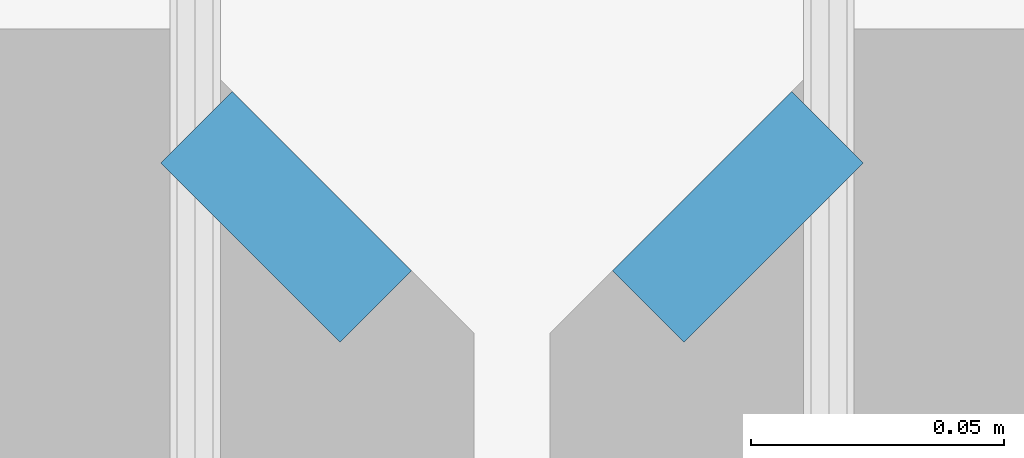
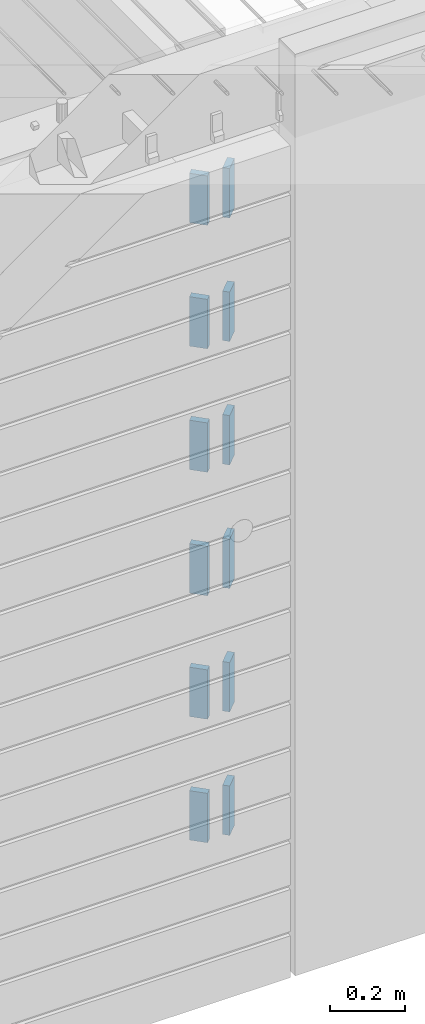
# One storey, part 206 of 341: 12 plates, 14 elements without a shape of their own.
"""IFC2X3 building model written with IfcOpenShell, lengths in millimetres."""

from ifc_helpers import new_model, si_unit, frame, origin_with_axes, place, context, subcontext, project, spatial, faceted_brep, material, type_object, element, aggregate, save


model = new_model("IFC2X3")

# Units and contexts
model_context = context("Model", 3, precision=1e-05, world=origin_with_axes())
body_context = subcontext(model_context, "Body", "Model", "MODEL_VIEW")
ifc_project = project(units=[si_unit("LENGTHUNIT", "METRE", prefix="MILLI"), si_unit("AREAUNIT", "SQUARE_METRE"), si_unit("VOLUMEUNIT", "CUBIC_METRE"), si_unit("MASSUNIT", "GRAM", prefix="KILO"), si_unit("TIMEUNIT", "SECOND"), si_unit("PLANEANGLEUNIT", "RADIAN"), si_unit("SOLIDANGLEUNIT", "STERADIAN"), si_unit("THERMODYNAMICTEMPERATUREUNIT", "DEGREE_CELSIUS"), si_unit("LUMINOUSINTENSITYUNIT", "LUMEN")], contexts=[model_context])

# Site, building, storey
site_placement = place(None, origin_with_axes())
site = spatial("IfcSite", under=ifc_project, at=site_placement, CompositionType="ELEMENT")
building_placement = place(site_placement, origin_with_axes())
building = spatial("IfcBuilding", under=site, at=building_placement, CompositionType="ELEMENT")
storey_placement = place(building_placement, origin_with_axes())
storey = spatial("IfcBuildingStorey", under=building, at=storey_placement, Name="5", CompositionType="ELEMENT", Elevation=0.0)

# Assemblies, plates
assembly_1_placement = place(storey_placement, origin_with_axes())
assembly_1 = element("IfcElementAssembly", 1, at=assembly_1_placement, inside=storey, AssemblyPlace="NOTDEFINED", PredefinedType="REINFORCEMENT_UNIT")
assembly_2_placement = place(assembly_1_placement, origin_with_axes())
assembly_2 = element("IfcElementAssembly", 2, at=assembly_2_placement, Name="Steel Assembly", AssemblyPlace="NOTDEFINED", PredefinedType="RIGID_FRAME")
ifc_material = material(Name="STEEL/Steel_Undefined")
plate_type = type_object("IfcPlateType", PredefinedType="NOTDEFINED")
plate_1_placement = place(assembly_2_placement, frame((28641.4644660941, 7938.1801948466, 96042.5), z_axis=(-0.707106781186547, 0.707106781186548, 0.0), x_axis=(0.707106781186557, 0.707106781186538, 0.0)))
plate_1 = element("IfcPlate", 3, at=plate_1_placement, type_object=plate_type, material=ifc_material, Name="VL_080", context=body_context, shape_type="Brep", body=[
    faceted_brep([(0.0, -80.0, 0.0), (0.0, -80.0, 20.0), (0.0, 80.0, 20.0), (0.0, 80.0, 0.0), (50.0, -80.0, 20.0), (50.0, 80.0, 20.0), (50.0, -80.0, 0.0), (50.0, 80.0, 0.0)], [[[0, 1, 2, 3]], [[1, 4, 5, 2]], [[4, 6, 7, 5]], [[6, 0, 3, 7]], [[5, 7, 3, 2]], [[6, 4, 1, 0]]]),
])
aggregate(assembly_2, [plate_1])
assembly_3_placement = place(assembly_1_placement, origin_with_axes())
assembly_3 = element("IfcElementAssembly", 4, at=assembly_3_placement, Name="Steel Assembly", AssemblyPlace="NOTDEFINED", PredefinedType="RIGID_FRAME")
plate_2_placement = place(assembly_3_placement, frame((28641.4644660941, 7938.1801948466, 95642.5), z_axis=(-0.707106781186547, 0.707106781186548, 0.0), x_axis=(0.707106781186557, 0.707106781186538, 0.0)))
plate_2 = element("IfcPlate", 5, at=plate_2_placement, type_object=plate_type, material=ifc_material, Name="VL_080", context=body_context, shape_type="Brep", body=[
    faceted_brep([(0.0, -80.0, 0.0), (0.0, -80.0, 20.0), (0.0, 80.0, 20.0), (0.0, 80.0, 0.0), (50.0, -80.0, 20.0), (50.0, 80.0, 20.0), (50.0, -80.0, 0.0), (50.0, 80.0, 0.0)], [[[0, 1, 2, 3]], [[1, 4, 5, 2]], [[4, 6, 7, 5]], [[6, 0, 3, 7]], [[5, 7, 3, 2]], [[6, 4, 1, 0]]]),
])
aggregate(assembly_3, [plate_2])
assembly_4_placement = place(assembly_1_placement, origin_with_axes())
assembly_4 = element("IfcElementAssembly", 6, at=assembly_4_placement, Name="Steel Assembly", AssemblyPlace="NOTDEFINED", PredefinedType="RIGID_FRAME")
plate_3_placement = place(assembly_4_placement, frame((28641.4644660941, 7938.1801948466, 95242.5), z_axis=(-0.707106781186547, 0.707106781186548, 0.0), x_axis=(0.707106781186557, 0.707106781186538, 0.0)))
plate_3 = element("IfcPlate", 7, at=plate_3_placement, type_object=plate_type, material=ifc_material, Name="VL_080", context=body_context, shape_type="Brep", body=[
    faceted_brep([(0.0, -80.0, 0.0), (0.0, -80.0, 20.0), (0.0, 80.0, 20.0), (0.0, 80.0, 0.0), (50.0, -80.0, 20.0), (50.0, 80.0, 20.0), (50.0, -80.0, 0.0), (50.0, 80.0, 0.0)], [[[0, 1, 2, 3]], [[1, 4, 5, 2]], [[4, 6, 7, 5]], [[6, 0, 3, 7]], [[5, 7, 3, 2]], [[6, 4, 1, 0]]]),
])
aggregate(assembly_4, [plate_3])

assembly_5_placement = place(storey_placement, origin_with_axes())
assembly_5 = element("IfcElementAssembly", 8, at=assembly_5_placement, inside=storey, AssemblyPlace="NOTDEFINED", PredefinedType="REINFORCEMENT_UNIT")
assembly_6_placement = place(assembly_5_placement, origin_with_axes())
assembly_6 = element("IfcElementAssembly", 9, at=assembly_6_placement, Name="Steel Assembly", AssemblyPlace="NOTDEFINED", PredefinedType="RIGID_FRAME")
plate_4_placement = place(assembly_6_placement, frame((28538.1801948466, 7973.53553390593, 96042.5), z_axis=(0.707106781186557, 0.707106781186538, 0.0), x_axis=(0.707106781186557, -0.707106781186538, 0.0)))
plate_4 = element("IfcPlate", 10, at=plate_4_placement, type_object=plate_type, material=ifc_material, Name="VL_080", context=body_context, shape_type="Brep", body=[
    faceted_brep([(0.0, -80.0, 0.0), (0.0, -80.0, 20.0), (0.0, 80.0, 20.0), (0.0, 80.0, 0.0), (50.0, -80.0, 20.0), (50.0, 80.0, 20.0), (50.0, -80.0, 0.0), (50.0, 80.0, 0.0)], [[[0, 1, 2, 3]], [[1, 4, 5, 2]], [[4, 6, 7, 5]], [[6, 0, 3, 7]], [[5, 7, 3, 2]], [[6, 4, 1, 0]]]),
])
aggregate(assembly_6, [plate_4])
assembly_7_placement = place(assembly_5_placement, origin_with_axes())
assembly_7 = element("IfcElementAssembly", 11, at=assembly_7_placement, Name="Steel Assembly", AssemblyPlace="NOTDEFINED", PredefinedType="RIGID_FRAME")
plate_5_placement = place(assembly_7_placement, frame((28538.1801948466, 7973.53553390593, 95642.5), z_axis=(0.707106781186557, 0.707106781186538, 0.0), x_axis=(0.707106781186557, -0.707106781186538, 0.0)))
plate_5 = element("IfcPlate", 12, at=plate_5_placement, type_object=plate_type, material=ifc_material, Name="VL_080", context=body_context, shape_type="Brep", body=[
    faceted_brep([(0.0, -80.0, 0.0), (0.0, -80.0, 20.0), (0.0, 80.0, 20.0), (0.0, 80.0, 0.0), (50.0, -80.0, 20.0), (50.0, 80.0, 20.0), (50.0, -80.0, 0.0), (50.0, 80.0, 0.0)], [[[0, 1, 2, 3]], [[1, 4, 5, 2]], [[4, 6, 7, 5]], [[6, 0, 3, 7]], [[5, 7, 3, 2]], [[6, 4, 1, 0]]]),
])
aggregate(assembly_7, [plate_5])
assembly_8_placement = place(assembly_5_placement, origin_with_axes())
assembly_8 = element("IfcElementAssembly", 13, at=assembly_8_placement, Name="Steel Assembly", AssemblyPlace="NOTDEFINED", PredefinedType="RIGID_FRAME")
plate_6_placement = place(assembly_8_placement, frame((28538.1801948466, 7973.53553390593, 95242.5), z_axis=(0.707106781186557, 0.707106781186538, 0.0), x_axis=(0.707106781186557, -0.707106781186538, 0.0)))
plate_6 = element("IfcPlate", 14, at=plate_6_placement, type_object=plate_type, material=ifc_material, Name="VL_080", context=body_context, shape_type="Brep", body=[
    faceted_brep([(0.0, -80.0, 0.0), (0.0, -80.0, 20.0), (0.0, 80.0, 20.0), (0.0, 80.0, 0.0), (50.0, -80.0, 20.0), (50.0, 80.0, 20.0), (50.0, -80.0, 0.0), (50.0, 80.0, 0.0)], [[[0, 1, 2, 3]], [[1, 4, 5, 2]], [[4, 6, 7, 5]], [[6, 0, 3, 7]], [[5, 7, 3, 2]], [[6, 4, 1, 0]]]),
])
aggregate(assembly_8, [plate_6])
assembly_9_placement = place(assembly_5_placement, origin_with_axes())
assembly_9 = element("IfcElementAssembly", 15, at=assembly_9_placement, Name="Steel Assembly", AssemblyPlace="NOTDEFINED", PredefinedType="RIGID_FRAME")
plate_7_placement = place(assembly_9_placement, frame((28538.1801948466, 7973.53553390592, 94842.5), z_axis=(0.707106781186557, 0.707106781186538, 0.0), x_axis=(0.707106781186557, -0.707106781186538, 0.0)))
plate_7 = element("IfcPlate", 16, at=plate_7_placement, type_object=plate_type, material=ifc_material, Name="VL_080", context=body_context, shape_type="Brep", body=[
    faceted_brep([(0.0, -80.0, 0.0), (0.0, -80.0, 20.0), (0.0, 80.0, 20.0), (0.0, 80.0, 0.0), (50.0, -80.0, 20.0), (50.0, 80.0, 20.0), (50.0, -80.0, 0.0), (50.0, 80.0, 0.0)], [[[0, 1, 2, 3]], [[1, 4, 5, 2]], [[4, 6, 7, 5]], [[6, 0, 3, 7]], [[5, 7, 3, 2]], [[6, 4, 1, 0]]]),
])
aggregate(assembly_9, [plate_7])
assembly_10_placement = place(assembly_5_placement, origin_with_axes())
assembly_10 = element("IfcElementAssembly", 17, at=assembly_10_placement, Name="Steel Assembly", AssemblyPlace="NOTDEFINED", PredefinedType="RIGID_FRAME")
plate_8_placement = place(assembly_10_placement, frame((28538.1801948466, 7973.53553390591, 94442.5), z_axis=(0.707106781186557, 0.707106781186538, 0.0), x_axis=(0.707106781186557, -0.707106781186538, 0.0)))
plate_8 = element("IfcPlate", 18, at=plate_8_placement, type_object=plate_type, material=ifc_material, Name="VL_080", context=body_context, shape_type="Brep", body=[
    faceted_brep([(0.0, -80.0, 0.0), (0.0, -80.0, 20.0), (0.0, 80.0, 20.0), (0.0, 80.0, 0.0), (50.0, -80.0, 20.0), (50.0, 80.0, 20.0), (50.0, -80.0, 0.0), (50.0, 80.0, 0.0)], [[[0, 1, 2, 3]], [[1, 4, 5, 2]], [[4, 6, 7, 5]], [[6, 0, 3, 7]], [[5, 7, 3, 2]], [[6, 4, 1, 0]]]),
])
aggregate(assembly_10, [plate_8])
assembly_11_placement = place(assembly_5_placement, origin_with_axes())
assembly_11 = element("IfcElementAssembly", 19, at=assembly_11_placement, Name="Steel Assembly", AssemblyPlace="NOTDEFINED", PredefinedType="RIGID_FRAME")
aggregate(assembly_5, [assembly_6, assembly_7, assembly_8, assembly_9, assembly_10, assembly_11])
plate_9_placement = place(assembly_11_placement, frame((28538.1801948466, 7973.53553390592, 94042.5), z_axis=(0.707106781186557, 0.707106781186538, 0.0), x_axis=(0.707106781186557, -0.707106781186538, 0.0)))
plate_9 = element("IfcPlate", 20, at=plate_9_placement, type_object=plate_type, material=ifc_material, Name="VL_080", context=body_context, shape_type="Brep", body=[
    faceted_brep([(0.0, -80.0, 0.0), (0.0, -80.0, 20.0), (0.0, 80.0, 20.0), (0.0, 80.0, 0.0), (50.0, -80.0, 20.0), (50.0, 80.0, 20.0), (50.0, -80.0, 0.0), (50.0, 80.0, 0.0)], [[[0, 1, 2, 3]], [[1, 4, 5, 2]], [[4, 6, 7, 5]], [[6, 0, 3, 7]], [[5, 7, 3, 2]], [[6, 4, 1, 0]]]),
])
aggregate(assembly_11, [plate_9])

# Assembly, plate
assembly_12_placement = place(assembly_1_placement, origin_with_axes())
assembly_12 = element("IfcElementAssembly", 21, at=assembly_12_placement, Name="Steel Assembly", AssemblyPlace="NOTDEFINED", PredefinedType="RIGID_FRAME")
plate_10_placement = place(assembly_12_placement, frame((28641.4644660941, 7938.18019484659, 94842.5), z_axis=(-0.707106781186547, 0.707106781186548, 0.0), x_axis=(0.707106781186557, 0.707106781186538, 0.0)))
plate_10 = element("IfcPlate", 22, at=plate_10_placement, type_object=plate_type, material=ifc_material, Name="VL_080", context=body_context, shape_type="Brep", body=[
    faceted_brep([(0.0, -80.0, 0.0), (0.0, -80.0, 20.0), (0.0, 80.0, 20.0), (0.0, 80.0, 0.0), (50.0, -80.0, 20.0), (50.0, 80.0, 20.0), (50.0, -80.0, 0.0), (50.0, 80.0, 0.0)], [[[0, 1, 2, 3]], [[1, 4, 5, 2]], [[4, 6, 7, 5]], [[6, 0, 3, 7]], [[5, 7, 3, 2]], [[6, 4, 1, 0]]]),
])
aggregate(assembly_12, [plate_10])

assembly_13_placement = place(assembly_1_placement, origin_with_axes())
assembly_13 = element("IfcElementAssembly", 23, at=assembly_13_placement, Name="Steel Assembly", AssemblyPlace="NOTDEFINED", PredefinedType="RIGID_FRAME")
plate_11_placement = place(assembly_13_placement, frame((28641.4644660941, 7938.1801948466, 94442.5), z_axis=(-0.707106781186547, 0.707106781186548, 0.0), x_axis=(0.707106781186557, 0.707106781186538, 0.0)))
plate_11 = element("IfcPlate", 24, at=plate_11_placement, type_object=plate_type, material=ifc_material, Name="VL_080", context=body_context, shape_type="Brep", body=[
    faceted_brep([(0.0, -80.0, 0.0), (0.0, -80.0, 20.0), (0.0, 80.0, 20.0), (0.0, 80.0, 0.0), (50.0, -80.0, 20.0), (50.0, 80.0, 20.0), (50.0, -80.0, 0.0), (50.0, 80.0, 0.0)], [[[0, 1, 2, 3]], [[1, 4, 5, 2]], [[4, 6, 7, 5]], [[6, 0, 3, 7]], [[5, 7, 3, 2]], [[6, 4, 1, 0]]]),
])
aggregate(assembly_13, [plate_11])

# Assembly
assembly_14_placement = place(assembly_1_placement, origin_with_axes())
assembly_14 = element("IfcElementAssembly", 25, at=assembly_14_placement, Name="Steel Assembly", AssemblyPlace="NOTDEFINED", PredefinedType="RIGID_FRAME")

aggregate(assembly_1, [assembly_2, assembly_3, assembly_4, assembly_12, assembly_13, assembly_14])

# Plate
plate_12_placement = place(assembly_14_placement, frame((28641.4644660941, 7938.1801948466, 94042.5), z_axis=(-0.707106781186547, 0.707106781186548, 0.0), x_axis=(0.707106781186557, 0.707106781186538, 0.0)))
plate_12 = element("IfcPlate", 26, at=plate_12_placement, type_object=plate_type, material=ifc_material, Name="VL_080", context=body_context, shape_type="Brep", body=[
    faceted_brep([(0.0, -80.0, 0.0), (0.0, -80.0, 20.0), (0.0, 80.0, 20.0), (0.0, 80.0, 0.0), (50.0, -80.0, 20.0), (50.0, 80.0, 20.0), (50.0, -80.0, 0.0), (50.0, 80.0, 0.0)], [[[0, 1, 2, 3]], [[1, 4, 5, 2]], [[4, 6, 7, 5]], [[6, 0, 3, 7]], [[5, 7, 3, 2]], [[6, 4, 1, 0]]]),
])

aggregate(assembly_14, [plate_12])

save(model, "model.ifc")
